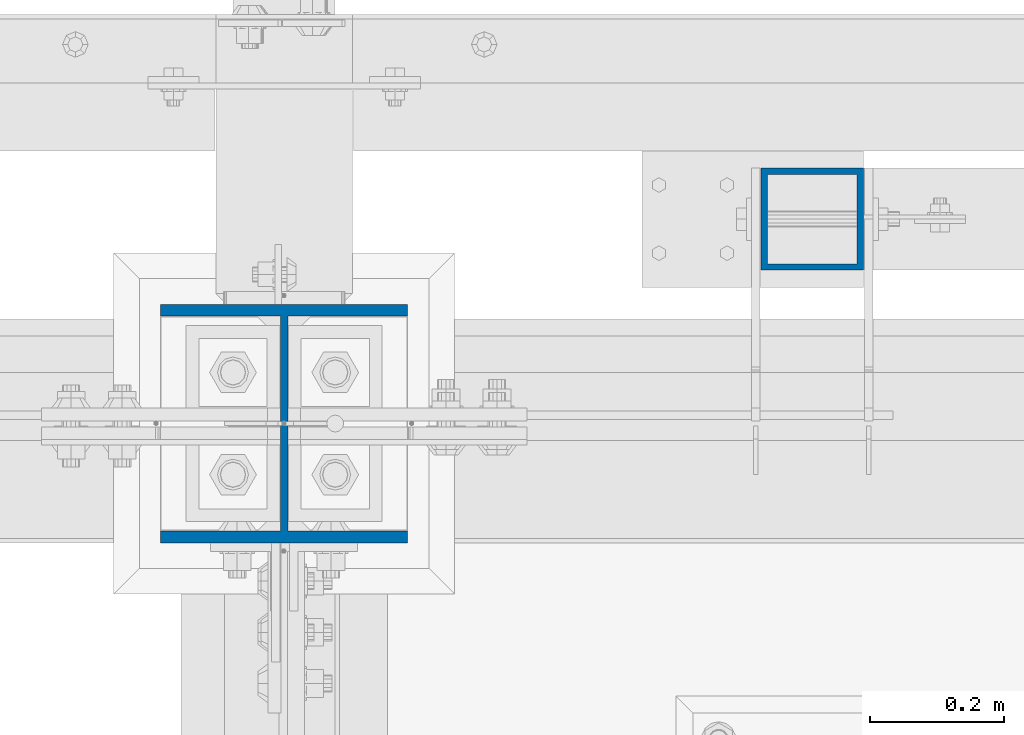
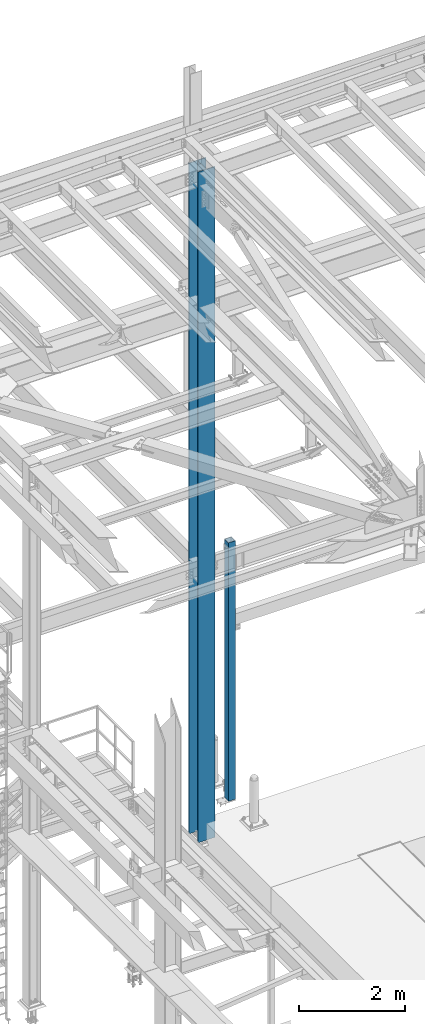
# One storey, part 1373 of 3843: 2 columns, 2 elements without a shape of their own.
"""IFC2X3 building model written with IfcOpenShell, lengths in millimetres."""

from ifc_helpers import new_model, si_unit, frame, origin_with_axes, place, context, subcontext, project, spatial, faceted_brep, material, type_object, element, aggregate, save


model = new_model("IFC2X3")

# Units and contexts
model_context = context("Model", 3, precision=1e-05, world=origin_with_axes())
body_context = subcontext(model_context, "Body", "Model", "MODEL_VIEW")
ifc_project = project(units=[si_unit("LENGTHUNIT", "METRE", prefix="MILLI"), si_unit("AREAUNIT", "SQUARE_METRE"), si_unit("VOLUMEUNIT", "CUBIC_METRE"), si_unit("MASSUNIT", "GRAM", prefix="KILO"), si_unit("TIMEUNIT", "SECOND"), si_unit("PLANEANGLEUNIT", "RADIAN"), si_unit("SOLIDANGLEUNIT", "STERADIAN"), si_unit("THERMODYNAMICTEMPERATUREUNIT", "DEGREE_CELSIUS"), si_unit("LUMINOUSINTENSITYUNIT", "LUMEN")], contexts=[model_context])

# Site, building, storey
site_placement = place(None, origin_with_axes())
site = spatial("IfcSite", under=ifc_project, at=site_placement, CompositionType="ELEMENT")
building_placement = place(site_placement, origin_with_axes())
building = spatial("IfcBuilding", under=site, at=building_placement, Name="Undefined", CompositionType="ELEMENT")
storey_placement = place(building_placement, origin_with_axes())
storey = spatial("IfcBuildingStorey", under=building, at=storey_placement, Name="Undefined", CompositionType="ELEMENT", Elevation=0.0)

# Assembly, column
assembly_1_placement = place(storey_placement, origin_with_axes())
assembly_1 = element("IfcElementAssembly", 1, at=assembly_1_placement, inside=storey, Name="POST", AssemblyPlace="NOTDEFINED", PredefinedType="RIGID_FRAME")
ifc_material_1 = material()
column_type_1 = type_object("IfcColumnType", Name="HSS6X6X3/8", PredefinedType="NOTDEFINED")
column_1_placement = place(assembly_1_placement, frame((42849.8, 92519.5, 30480.0), z_axis=(0.0, 1.0, 0.0), x_axis=(0.0, 0.0, 1.0)))
column_1 = element("IfcColumn", 2, at=column_1_placement, type_object=column_type_1, material=ifc_material_1, Name="POST", ObjectType="HSS6X6X3/8", context=body_context, shape_type="Brep", body=[
    faceted_brep([(12.7000000000007, 66.6750000000029, -66.6750000000029), (12.7000000000007, -66.6750000000029, -66.6750000000029), (5949.95, -66.6750000000029, -66.6750000000029), (5949.95, 66.6750000000029, -66.6750000000029), (12.7000000000007, -66.6750000000029, 66.6750000000029), (5949.95, -66.6750000000029, 66.6750000000029), (12.7000000000007, 66.6750000000029, 66.6750000000029), (5949.95, 66.6750000000029, 66.6750000000029), (12.7000000000007, 76.1999999999971, -76.1999999999971), (12.7000000000007, 76.1999999999971, 76.1999999999971), (5949.95, 76.1999999999971, 76.1999999999971), (5949.95, 76.1999999999971, -76.1999999999971), (12.7000000000007, -76.1999999999971, 76.1999999999971), (5949.95, -76.1999999999971, 76.1999999999971), (12.7000000000007, -76.1999999999971, -76.1999999999971), (5949.95, -76.1999999999971, -76.1999999999971)], [[[0, 1, 2, 3]], [[1, 4, 5, 2]], [[4, 6, 7, 5]], [[6, 0, 3, 7]], [[8, 9, 10, 11]], [[9, 12, 13, 10]], [[12, 14, 15, 13]], [[14, 8, 11, 15]], [[13, 15, 11, 10], [5, 7, 3, 2]], [[14, 12, 9, 8], [6, 4, 1, 0]]]),
])
aggregate(assembly_1, [column_1])

assembly_2_placement = place(storey_placement, origin_with_axes())
assembly_2 = element("IfcElementAssembly", 3, at=assembly_2_placement, inside=storey, Name="COLUMN", AssemblyPlace="NOTDEFINED", PredefinedType="RIGID_FRAME")
ifc_material_2 = material(Name="STEEL/A992")
column_type_2 = type_object("IfcColumnType", Name="W14X90", PredefinedType="NOTDEFINED")
column_2_placement = place(assembly_2_placement, frame((42062.4, 92214.7, 30022.8), z_axis=(0.0, 1.0, 0.0), x_axis=(0.0, 0.0, 1.0)))
column_2 = element("IfcColumn", 4, at=column_2_placement, type_object=column_type_2, material=ifc_material_2, Name="COLUMN", ObjectType="W14X90", context=body_context, shape_type="Brep", body=[
    faceted_brep([(76.2000000000007, 184.149999999994, -177.799999999999), (76.2000000000007, 184.149999999994, -160.337500000001), (15490.8537343155, 184.150000000001, -160.337499999994), (15490.8537343155, 184.150000000001, -177.800000000003), (76.2000000000007, 5.55624999999418, -160.337500000001), (15490.8537343155, 5.55625000000146, -160.337499999994), (76.2000000000007, 5.55624999999418, 160.337500000001), (15490.8537343155, 5.55625000000146, 160.337499999994), (76.2000000000007, 184.149999999994, 160.337500000001), (15490.8537343155, 184.150000000001, 160.337499999994), (76.2000000000007, 184.149999999994, 177.799999999999), (15490.8537343155, 184.150000000001, 177.800000000003), (76.2000000000007, -184.149999999994, 177.799999999999), (15490.8537343155, -184.150000000001, 177.800000000003), (76.2000000000007, -184.149999999994, 160.337500000001), (15490.8537343155, -184.150000000001, 160.337499999994), (76.2000000000007, -5.55624999999418, 160.337500000001), (15490.8537343155, -5.55625000000146, 160.337499999994), (76.2000000000007, -5.55624999999418, -160.337500000001), (15490.8537343155, -5.55625000000146, -160.337499999994), (76.2000000000007, -184.149999999994, -160.337500000001), (15490.8537343155, -184.150000000001, -160.337499999994), (76.2000000000007, -184.149999999994, -177.799999999999), (15490.8537343155, -184.150000000001, -177.800000000003)], [[[0, 1, 2, 3]], [[1, 4, 5, 2]], [[4, 6, 7, 5]], [[6, 8, 9, 7]], [[8, 10, 11, 9]], [[10, 12, 13, 11]], [[12, 14, 15, 13]], [[14, 16, 17, 15]], [[16, 18, 19, 17]], [[18, 20, 21, 19]], [[20, 22, 23, 21]], [[22, 0, 3, 23]], [[5, 7, 9, 11, 13, 15, 17, 19, 21, 23, 3, 2]], [[22, 20, 18, 16, 14, 12, 10, 8, 6, 4, 1, 0]]]),
])
aggregate(assembly_2, [column_2])

save(model, "model.ifc")
